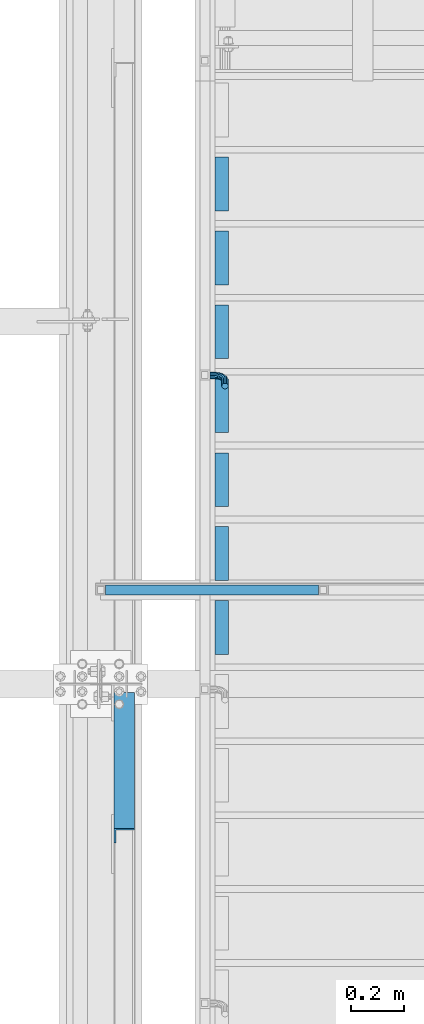
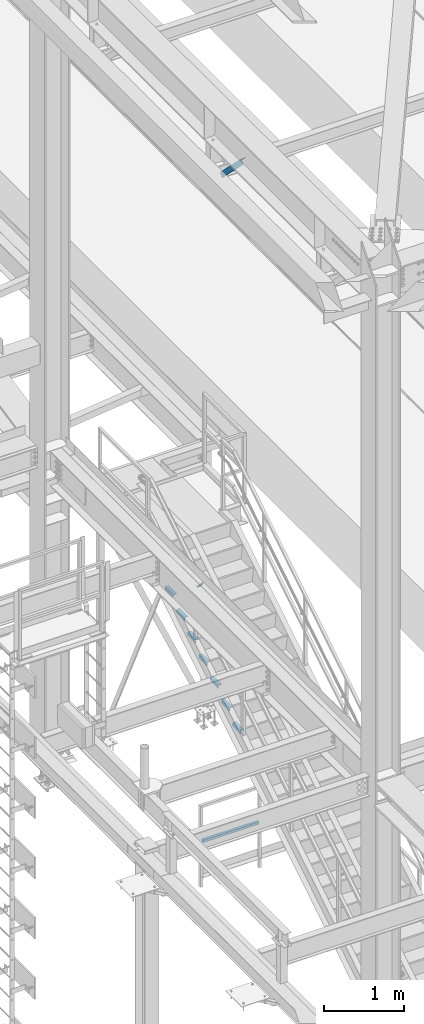
# One storey, part 2017 of 3843: 9 beams, 1 member, 4 elements without a shape of their own.
"""IFC2X3 building model written with IfcOpenShell, lengths in millimetres."""

from ifc_helpers import new_model, si_unit, frame, origin_with_axes, place, context, subcontext, project, spatial, faceted_brep, material, type_object, element, aggregate, save


model = new_model("IFC2X3")

# Units and contexts
model_context = context("Model", 3, precision=1e-05, world=origin_with_axes())
body_context = subcontext(model_context, "Body", "Model", "MODEL_VIEW")
ifc_project = project(units=[si_unit("LENGTHUNIT", "METRE", prefix="MILLI"), si_unit("AREAUNIT", "SQUARE_METRE"), si_unit("VOLUMEUNIT", "CUBIC_METRE"), si_unit("MASSUNIT", "GRAM", prefix="KILO"), si_unit("TIMEUNIT", "SECOND"), si_unit("PLANEANGLEUNIT", "RADIAN"), si_unit("SOLIDANGLEUNIT", "STERADIAN"), si_unit("THERMODYNAMICTEMPERATUREUNIT", "DEGREE_CELSIUS"), si_unit("LUMINOUSINTENSITYUNIT", "LUMEN")], contexts=[model_context])

# Site, building, storey
site_placement = place(None, origin_with_axes())
site = spatial("IfcSite", under=ifc_project, at=site_placement, CompositionType="ELEMENT")
building_placement = place(site_placement, origin_with_axes())
building = spatial("IfcBuilding", under=site, at=building_placement, Name="Undefined", CompositionType="ELEMENT")
storey_placement = place(building_placement, origin_with_axes())
storey = spatial("IfcBuildingStorey", under=building, at=storey_placement, Name="Undefined", CompositionType="ELEMENT", Elevation=0.0)

# Assembly, beam
assembly_1_placement = place(storey_placement, origin_with_axes())
assembly_1 = element("IfcElementAssembly", 1, at=assembly_1_placement, inside=storey, Name="RAIL", AssemblyPlace="NOTDEFINED", PredefinedType="RIGID_FRAME")
ifc_material_1 = material()
beam_type_1 = type_object("IfcBeamType", Name="HSS1-1/2X1-1/2X1/4", PredefinedType="NOTDEFINED")
beam_1_placement = place(assembly_1_placement, frame((37417.375, 30086.2999999812, 31013.4), z_axis=(0.0, 0.0, 1.0), x_axis=(-1.0, 0.0, 0.0)))
beam_1 = element("IfcBeam", 2, at=beam_1_placement, type_object=beam_type_1, material=ifc_material_1, Name="RAIL", ObjectType="HSS1-1/2X1-1/2X1/4", context=body_context, shape_type="Brep", body=[
    faceted_brep([(822.325000000004, -19.0499999999993, 19.0499992350015), (822.325000000004, -19.0499992350015, -19.0499992350015), (822.325000000004, 19.0499992350015, -19.0499992350015), (822.325000000004, 19.0499992350015, 19.0499992350015), (822.325000000004, -12.6999993300014, 12.6999993300014), (822.325000000004, 12.6999993300014, 12.6999993300014), (822.325000000004, 12.6999993300014, -12.6999993300014), (822.325000000004, -12.6999993300014, -12.6999993300014), (19.0499992350015, 19.0499992350015, -19.0499992350015), (19.0499992350015, 19.0499992350015, 19.0499992350015), (19.0499992350015, -19.0499992350015, 19.0499992350015), (19.0499992350015, -19.0499992350015, -19.0499992350015), (19.0499992350015, 12.6999993299978, 12.6999993299978), (19.0499992350015, -12.6999993299978, 12.6999993299978), (19.0499992350015, -12.6999993299978, -12.6999993299978), (19.0499992350015, 12.6999993299978, -12.6999993299978)], [[[0, 1, 2, 3], [4, 5, 6, 7]], [[8, 9, 3, 2]], [[9, 10, 0, 3]], [[10, 11, 1, 0]], [[11, 8, 2, 1]], [[11, 10, 9, 8], [12, 13, 14, 15]], [[14, 13, 4, 7]], [[15, 14, 7, 6]], [[12, 15, 6, 5]], [[13, 12, 5, 4]]]),
])
aggregate(assembly_1, [beam_1])

# Assembly, beams
assembly_2_placement = place(storey_placement, origin_with_axes())
assembly_2 = element("IfcElementAssembly", 3, at=assembly_2_placement, inside=storey, Name="STAIR", AssemblyPlace="NOTDEFINED", PredefinedType="RIGID_FRAME")
ifc_material_2 = material(Name="STEEL/A36")
beam_type_2 = type_object("IfcBeamType", Name="L2X2X3/16", PredefinedType="NOTDEFINED")
beam_2_placement = place(assembly_2_placement, frame((37033.1999999894, 31519.3169176331, 33709.8821428628), z_axis=(1.0, 0.0, 0.0), x_axis=(0.0, 1.0, 0.0)))
beam_2 = element("IfcBeam", 4, at=beam_2_placement, type_object=beam_type_2, material=ifc_material_2, Name="ANGLE", ObjectType="L2X2X3/16", context=body_context, shape_type="Brep", body=[
    faceted_brep([(0.0, 25.4000000000015, -25.4000000000015), (0.0, 25.4000000000015, 25.4000000000015), (203.199999999997, 25.4000000000015, 25.4000000000015), (203.199999999997, 25.4000000000015, -25.4000000000015), (0.0, 20.6375000000007, 25.4000000000015), (203.199999999997, 20.6375000000007, 25.4000000000015), (0.0, 20.6375000000007, -20.6375000000007), (203.199999999997, 20.6375000000007, -20.6375000000007), (0.0, -25.4000000000015, -20.6375000000007), (203.199999999997, -25.4000000000015, -20.6375000000007), (0.0, -25.4000000000015, -25.4000000000015), (203.199999999997, -25.4000000000015, -25.4000000000015)], [[[0, 1, 2, 3]], [[1, 4, 5, 2]], [[4, 6, 7, 5]], [[6, 8, 9, 7]], [[8, 10, 11, 9]], [[10, 0, 3, 11]], [[5, 7, 9, 11, 3, 2]], [[10, 8, 6, 4, 1, 0]]]),
])
beam_3_placement = place(assembly_2_placement, frame((37033.1999999894, 31239.9169176322, 33535.7107142914), z_axis=(1.0, 0.0, 0.0), x_axis=(0.0, 1.0, 0.0)))
beam_3 = element("IfcBeam", 5, at=beam_3_placement, type_object=beam_type_2, material=ifc_material_2, Name="ANGLE", ObjectType="L2X2X3/16", context=body_context, shape_type="Brep", body=[
    faceted_brep([(0.0, 25.4000000000015, -25.4000000000015), (0.0, 25.4000000000015, 25.4000000000015), (203.199999999997, 25.4000000000015, 25.4000000000015), (203.199999999997, 25.4000000000015, -25.4000000000015), (0.0, 20.6375000000007, 25.4000000000015), (203.199999999997, 20.6375000000007, 25.4000000000015), (0.0, 20.6375000000007, -20.6375000000007), (203.199999999997, 20.6375000000007, -20.6375000000007), (0.0, -25.4000000000015, -20.6375000000007), (203.199999999997, -25.4000000000015, -20.6375000000007), (0.0, -25.4000000000015, -25.4000000000015), (203.199999999997, -25.4000000000015, -25.4000000000015)], [[[0, 1, 2, 3]], [[1, 4, 5, 2]], [[4, 6, 7, 5]], [[6, 8, 9, 7]], [[8, 10, 11, 9]], [[10, 0, 3, 11]], [[5, 7, 9, 11, 3, 2]], [[10, 8, 6, 4, 1, 0]]]),
])
beam_4_placement = place(assembly_2_placement, frame((37033.1999999894, 30960.5169176314, 33361.5392857199), z_axis=(1.0, 0.0, 0.0), x_axis=(0.0, 1.0, 0.0)))
beam_4 = element("IfcBeam", 6, at=beam_4_placement, type_object=beam_type_2, material=ifc_material_2, Name="ANGLE", ObjectType="L2X2X3/16", context=body_context, shape_type="Brep", body=[
    faceted_brep([(0.0, 25.4000000000015, -25.4000000000015), (0.0, 25.4000000000015, 25.4000000000015), (203.199999999997, 25.4000000000015, 25.4000000000015), (203.199999999997, 25.4000000000015, -25.4000000000015), (0.0, 20.6375000000007, 25.4000000000015), (203.199999999997, 20.6375000000007, 25.4000000000015), (0.0, 20.6375000000007, -20.6375000000007), (203.199999999997, 20.6375000000007, -20.6375000000007), (0.0, -25.4000000000015, -20.6375000000007), (203.199999999997, -25.4000000000015, -20.6375000000007), (0.0, -25.4000000000015, -25.4000000000015), (203.199999999997, -25.4000000000015, -25.4000000000015)], [[[0, 1, 2, 3]], [[1, 4, 5, 2]], [[4, 6, 7, 5]], [[6, 8, 9, 7]], [[8, 10, 11, 9]], [[10, 0, 3, 11]], [[5, 7, 9, 11, 3, 2]], [[10, 8, 6, 4, 1, 0]]]),
])
beam_5_placement = place(assembly_2_placement, frame((37033.1999999894, 30681.1169176306, 33187.3678571485), z_axis=(1.0, 0.0, 0.0), x_axis=(0.0, 1.0, 0.0)))
beam_5 = element("IfcBeam", 7, at=beam_5_placement, type_object=beam_type_2, material=ifc_material_2, Name="ANGLE", ObjectType="L2X2X3/16", context=body_context, shape_type="Brep", body=[
    faceted_brep([(0.0, 25.4000000000015, -25.4000000000015), (0.0, 25.4000000000015, 25.4000000000015), (203.199999999997, 25.4000000000015, 25.4000000000015), (203.199999999997, 25.4000000000015, -25.4000000000015), (0.0, 20.6375000000007, 25.4000000000015), (203.199999999997, 20.6375000000007, 25.4000000000015), (0.0, 20.6375000000007, -20.6375000000007), (203.199999999997, 20.6375000000007, -20.6375000000007), (0.0, -25.4000000000015, -20.6375000000007), (203.199999999997, -25.4000000000015, -20.6375000000007), (0.0, -25.4000000000015, -25.4000000000015), (203.199999999997, -25.4000000000015, -25.4000000000015)], [[[0, 1, 2, 3]], [[1, 4, 5, 2]], [[4, 6, 7, 5]], [[6, 8, 9, 7]], [[8, 10, 11, 9]], [[10, 0, 3, 11]], [[5, 7, 9, 11, 3, 2]], [[10, 8, 6, 4, 1, 0]]]),
])
beam_6_placement = place(assembly_2_placement, frame((37033.1999999894, 30401.7169176297, 33013.1964285771), z_axis=(1.0, 0.0, 0.0), x_axis=(0.0, 1.0, 0.0)))
beam_6 = element("IfcBeam", 8, at=beam_6_placement, type_object=beam_type_2, material=ifc_material_2, Name="ANGLE", ObjectType="L2X2X3/16", context=body_context, shape_type="Brep", body=[
    faceted_brep([(0.0, 25.4000000000015, -25.4000000000015), (0.0, 25.4000000000015, 25.4000000000015), (203.199999999997, 25.4000000000015, 25.4000000000015), (203.199999999997, 25.4000000000015, -25.4000000000015), (0.0, 20.6375000000007, 25.4000000000015), (203.199999999997, 20.6375000000007, 25.4000000000015), (0.0, 20.6375000000007, -20.6375000000007), (203.199999999997, 20.6375000000007, -20.6375000000007), (0.0, -25.4000000000015, -20.6375000000007), (203.199999999997, -25.4000000000015, -20.6375000000007), (0.0, -25.4000000000015, -25.4000000000015), (203.199999999997, -25.4000000000015, -25.4000000000015)], [[[0, 1, 2, 3]], [[1, 4, 5, 2]], [[4, 6, 7, 5]], [[6, 8, 9, 7]], [[8, 10, 11, 9]], [[10, 0, 3, 11]], [[5, 7, 9, 11, 3, 2]], [[10, 8, 6, 4, 1, 0]]]),
])
beam_7_placement = place(assembly_2_placement, frame((37033.1999999894, 30122.3169176289, 32839.0250000057), z_axis=(1.0, 0.0, 0.0), x_axis=(0.0, 1.0, 0.0)))
beam_7 = element("IfcBeam", 9, at=beam_7_placement, type_object=beam_type_2, material=ifc_material_2, Name="ANGLE", ObjectType="L2X2X3/16", context=body_context, shape_type="Brep", body=[
    faceted_brep([(0.0, 25.4000000000015, -25.4000000000015), (0.0, 25.4000000000015, 25.4000000000015), (203.199999999997, 25.4000000000015, 25.4000000000015), (203.199999999997, 25.4000000000015, -25.4000000000015), (0.0, 20.6375000000007, 25.4000000000015), (203.199999999997, 20.6375000000007, 25.4000000000015), (0.0, 20.6375000000007, -20.6375000000007), (203.199999999997, 20.6375000000007, -20.6375000000007), (0.0, -25.4000000000015, -20.6375000000007), (203.199999999997, -25.4000000000015, -20.6375000000007), (0.0, -25.4000000000015, -25.4000000000015), (203.199999999997, -25.4000000000015, -25.4000000000015)], [[[0, 1, 2, 3]], [[1, 4, 5, 2]], [[4, 6, 7, 5]], [[6, 8, 9, 7]], [[8, 10, 11, 9]], [[10, 0, 3, 11]], [[5, 7, 9, 11, 3, 2]], [[10, 8, 6, 4, 1, 0]]]),
])
beam_8_placement = place(assembly_2_placement, frame((37033.1999999894, 29842.9169176281, 32664.8535714342), z_axis=(1.0, 0.0, 0.0), x_axis=(0.0, 1.0, 0.0)))
beam_8 = element("IfcBeam", 10, at=beam_8_placement, type_object=beam_type_2, material=ifc_material_2, Name="ANGLE", ObjectType="L2X2X3/16", context=body_context, shape_type="Brep", body=[
    faceted_brep([(0.0, 25.4000000000015, -25.4000000000015), (0.0, 25.4000000000015, 25.4000000000015), (203.199999999997, 25.4000000000015, 25.4000000000015), (203.199999999997, 25.4000000000015, -25.4000000000015), (0.0, 20.6375000000007, 25.4000000000015), (203.199999999997, 20.6375000000007, 25.4000000000015), (0.0, 20.6375000000007, -20.6375000000007), (203.199999999997, 20.6375000000007, -20.6375000000007), (0.0, -25.4000000000015, -20.6375000000007), (203.199999999997, -25.4000000000015, -20.6375000000007), (0.0, -25.4000000000015, -25.4000000000015), (203.199999999997, -25.4000000000015, -25.4000000000015)], [[[0, 1, 2, 3]], [[1, 4, 5, 2]], [[4, 6, 7, 5]], [[6, 8, 9, 7]], [[8, 10, 11, 9]], [[10, 0, 3, 11]], [[5, 7, 9, 11, 3, 2]], [[10, 8, 6, 4, 1, 0]]]),
])
aggregate(assembly_2, [beam_2, beam_3, beam_4, beam_5, beam_6, beam_7, beam_8])

# Assembly, beam
assembly_3_placement = place(storey_placement, origin_with_axes())
assembly_3 = element("IfcElementAssembly", 11, at=assembly_3_placement, inside=storey, Name="RAIL", AssemblyPlace="NOTDEFINED", PredefinedType="RIGID_FRAME")
beam_type_3 = type_object("IfcBeamType", PredefinedType="NOTDEFINED")
beam_9_placement = place(assembly_3_placement, frame((36988.7499999524, 30897.3022284292, 34241.9521339868), z_axis=(0.0, -0.848616882600525, -0.529007926750977), x_axis=(1.0, 0.0, 0.0)))
beam_9 = element("IfcBeam", 12, at=beam_9_placement, type_object=beam_type_3, material=ifc_material_2, Name="BRACKET ARM", context=body_context, shape_type="Brep", body=[
    faceted_brep([(0.0, -12.6999999999971, 0.0), (0.0, -10.9985226280696, -6.34999999999854), (19.0500015258731, -10.9985226280623, -6.34999999999854), (19.0500015258731, -12.6999999999971, -6.33008312433958e-10), (0.0, -6.35000000000582, -10.9985226280623), (19.0500015258731, -6.34999999999854, -10.9985226280623), (0.0, 0.0, -12.6999999999971), (19.0500015258731, 0.0, -12.6999999999971), (0.0, 6.35000000000582, -10.9985226280623), (19.0500015258731, 6.34999999999854, -10.9985226280623), (0.0, 10.9985226280696, -6.34999999999854), (19.0500015258731, 10.9985226280623, -6.34999999999854), (0.0, 12.6999999999971, 0.0), (19.0500015258731, 12.6999999999971, 0.0), (0.0, 10.9985226280696, 6.34999999999854), (19.0500015258731, 10.9985226280623, 6.34999999999854), (0.0, 6.35000000000582, 10.9985226280623), (19.0500015258731, 6.34999999999854, 10.9985226280623), (0.0, 0.0, 12.6999999999971), (19.0500015258731, 0.0, 12.6999999999971), (0.0, -6.35000000000582, 10.9985226280623), (19.0500015258731, -6.34999999999854, 10.9985226280623), (0.0, -10.9985226280696, 6.34999999999854), (19.0500015258731, -10.9985226280623, 6.34999999999854), (38.4903193060891, -8.8330803677236, -3.34694050252438e-10), (37.8391921052389, -7.26112024908798, 6.34999999974389), (36.0602795104642, -2.96644533684594, 10.9985226280041), (33.6302397149266, 2.90018969451194, 12.7000000002226), (31.2001999194181, 8.76682472604443, 10.9985226285644), (29.4212873247307, 13.061499638774, 6.35000000070431), (28.7701601240115, 14.6334597580644, 7.78527464717627e-10), (29.4212873248762, 13.0614996394288, -6.34999999929278), (31.2001999196509, 8.76682472718676, -10.9985226275603), (33.6302397151885, 2.90018969582889, -12.6999999997788), (36.0602795106824, -2.96644533571089, -10.9985226281206), (37.8391921053699, -7.26112024843314, -6.35000000026048), (53.7678987435793, 3.38210125690239, -6.3499999994383), (54.9710249311902, 2.17897506880399, 5.0931703299284e-10), (50.4808968708676, 6.66910312997061, -10.9985226273784), (45.9907688103704, 11.1592311906061, -12.6999999991458), (41.5006407498004, 15.6493592510378, -10.9985226270364), (38.213638876914, 18.9363611235749, -6.34999999884167), (37.0105126890558, 20.1394873109457, 1.20053300634027e-09), (38.2136388766667, 18.9363611228473, 6.35000000115542), (41.5006407493784, 15.6493592497718, 10.9985226290883), (45.9907688098756, 11.1592311891436, 12.7000000008557), (50.4808968704456, 6.66910312870459, 10.9985226287463), (53.7678987433319, 3.38210125617479, 6.35000000055879), (64.4111202489148, 19.3108078951118, -6.34999999821594), (65.9830803677178, 18.6596806939051, 1.77533365786076e-09), (60.1164453365491, 21.0897204901557, -10.9985226262725), (54.2498103051475, 23.5197602857806, -12.6999999981927), (48.3831752736587, 25.9498000811873, -10.9985226262434), (44.0885003610601, 27.7287126756128, -6.34999999817228), (42.516540241937, 28.3798398759754, 1.83354131877422e-09), (44.08850036074, 27.7287126747688, 6.35000000183209), (48.3831752731057, 25.9498000797321, 10.9985226298813), (54.2498103045073, 23.5197602840999, 12.7000000018088), (60.1164453359961, 21.0897204886933, 10.9985226298522), (64.4111202485947, 19.3108078942678, 6.35000000178115), (68.1485226282239, 38.0999984746086, -6.3499999967753), (69.8499999999913, 38.0999984741211, 2.92493496090174e-09), (63.500000000291, 38.0999984749651, -10.9985226249628), (57.1500000003434, 38.0999984750961, -12.6999999970722), (50.8000000002939, 38.0999984749651, -10.998522625312), (46.1514773720992, 38.0999984746086, -6.34999999737192), (44.4499999999971, 38.0999984741211, 2.58296495303512e-09), (46.1514773717645, 38.0999984736336, 6.35000000262517), (50.7999999996973, 38.0999984732771, 10.9985226308127), (57.1499999996449, 38.0999984731461, 12.700000002922), (63.4999999996944, 38.0999984732771, 10.9985226311619), (68.1485226278892, 38.0999984736336, 6.35000000322179), (68.1485226280638, 76.2000000002372, -6.34999999414867), (69.8499999999913, 76.199999999757, 5.84986992180347e-09), (63.5, 76.200000000601, -10.9985226222125), (57.1499999999942, 76.2000000007247, -12.6999999941472), (50.7999999999884, 76.200000000601, -10.9985226222125), (46.1514773719246, 76.2000000002372, -6.34999999414867), (44.4499999999971, 76.199999999757, 5.84986992180347e-09), (46.1514773719246, 76.1999999992695, 6.35000000584841), (50.7999999999884, 76.1999999989057, 10.9985226339122), (57.1499999999942, 76.199999998782, 12.700000005847), (63.5, 76.1999999989057, 10.9985226339122), (68.1485226280638, 76.1999999992695, 6.35000000584841)], [[[0, 1, 2, 3]], [[1, 4, 5, 2]], [[4, 6, 7, 5]], [[6, 8, 9, 7]], [[8, 10, 11, 9]], [[10, 12, 13, 11]], [[12, 14, 15, 13]], [[14, 16, 17, 15]], [[16, 18, 19, 17]], [[18, 20, 21, 19]], [[20, 22, 23, 21]], [[22, 0, 3, 23]], [[22, 20, 18, 16, 14, 12, 10, 8, 6, 4, 1, 0]], [[23, 3, 24, 25]], [[21, 23, 25, 26]], [[19, 21, 26, 27]], [[17, 19, 27, 28]], [[15, 17, 28, 29]], [[13, 15, 29, 30]], [[11, 13, 30, 31]], [[9, 11, 31, 32]], [[7, 9, 32, 33]], [[5, 7, 33, 34]], [[2, 5, 34, 35]], [[3, 2, 35, 24]], [[35, 36, 37, 24]], [[34, 38, 36, 35]], [[33, 39, 38, 34]], [[32, 40, 39, 33]], [[31, 41, 40, 32]], [[30, 42, 41, 31]], [[29, 43, 42, 30]], [[28, 44, 43, 29]], [[27, 45, 44, 28]], [[26, 46, 45, 27]], [[25, 47, 46, 26]], [[24, 37, 47, 25]], [[36, 48, 49, 37]], [[38, 50, 48, 36]], [[39, 51, 50, 38]], [[40, 52, 51, 39]], [[41, 53, 52, 40]], [[42, 54, 53, 41]], [[43, 55, 54, 42]], [[44, 56, 55, 43]], [[45, 57, 56, 44]], [[46, 58, 57, 45]], [[47, 59, 58, 46]], [[37, 49, 59, 47]], [[48, 60, 61, 49]], [[50, 62, 60, 48]], [[51, 63, 62, 50]], [[52, 64, 63, 51]], [[53, 65, 64, 52]], [[54, 66, 65, 53]], [[55, 67, 66, 54]], [[56, 68, 67, 55]], [[57, 69, 68, 56]], [[58, 70, 69, 57]], [[59, 71, 70, 58]], [[49, 61, 71, 59]], [[61, 60, 72, 73]], [[60, 62, 74, 72]], [[62, 63, 75, 74]], [[63, 64, 76, 75]], [[64, 65, 77, 76]], [[65, 66, 78, 77]], [[66, 67, 79, 78]], [[67, 68, 80, 79]], [[68, 69, 81, 80]], [[69, 70, 82, 81]], [[70, 71, 83, 82]], [[71, 61, 73, 83]], [[74, 75, 76, 77, 78, 79, 80, 81, 82, 83, 73, 72]]]),
])
aggregate(assembly_3, [beam_9])

# Assembly, member
assembly_4_placement = place(storey_placement, origin_with_axes())
assembly_4 = element("IfcElementAssembly", 13, at=assembly_4_placement, inside=storey, Name="ANGLE", AssemblyPlace="NOTDEFINED", PredefinedType="RIGID_FRAME")
ifc_material_3 = material(Name="STEEL/A572-50")
member_type = type_object("IfcMemberType", Name="L3X3X1/4", PredefinedType="NOTDEFINED")
member_placement = place(assembly_4_placement, frame((36664.9, 29730.7, 41300.4), z_axis=(0.0, -0.707106781186548, -0.707106781186548), x_axis=(0.0, -0.707106781186682, 0.707106781186413)))
member = element("IfcMember", 14, at=member_placement, type_object=member_type, material=ifc_material_3, Name="ANGLE", ObjectType="L3X3X1/4", context=body_context, shape_type="Brep", body=[
    faceted_brep([(83.0012806675732, 38.0999999999985, -38.0999999999058), (83.0012806675732, -38.0999999999985, -38.0999999999058), (83.0012806675804, -38.0999999999985, -31.7499999999254), (83.0012806675804, 31.75, -31.7499999999254), (83.0012806675804, 31.75, 38.0999999999058), (83.0012806675804, 38.0999999999985, 38.0999999999058), (810.534203444928, 31.75, 38.0999999999112), (810.534203444928, 38.0999999999985, 38.0999999999112), (810.534203444538, 38.0999999999985, -38.099999999904), (810.534203444538, -38.0999999999985, -38.099999999904), (810.534203444575, -38.0999999999985, -31.7499999999272), (810.534203444575, 31.75, -31.7499999999272)], [[[0, 1, 2, 3, 4, 5]], [[5, 4, 6, 7]], [[0, 5, 7, 8]], [[1, 0, 8, 9]], [[2, 1, 9, 10]], [[3, 2, 10, 11]], [[4, 3, 11, 6]], [[10, 9, 8, 7, 6, 11]]]),
])
aggregate(assembly_4, [member])

save(model, "model.ifc")
